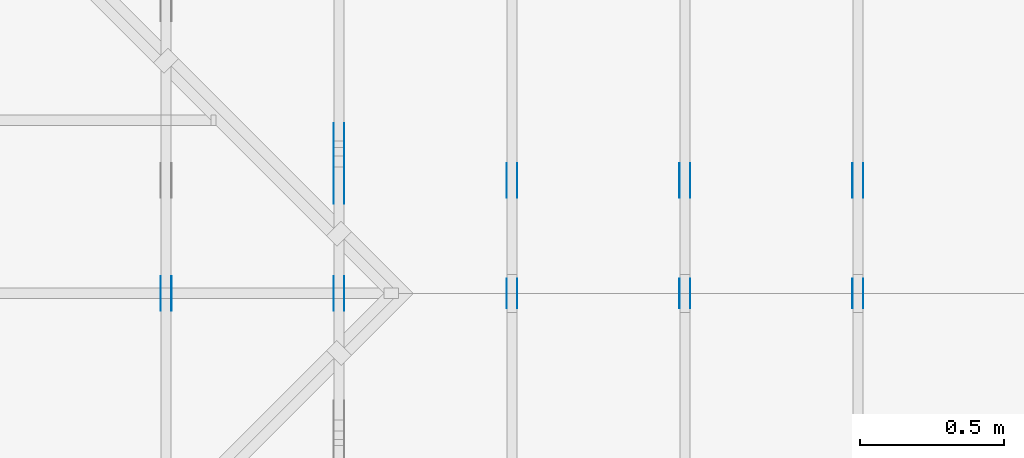
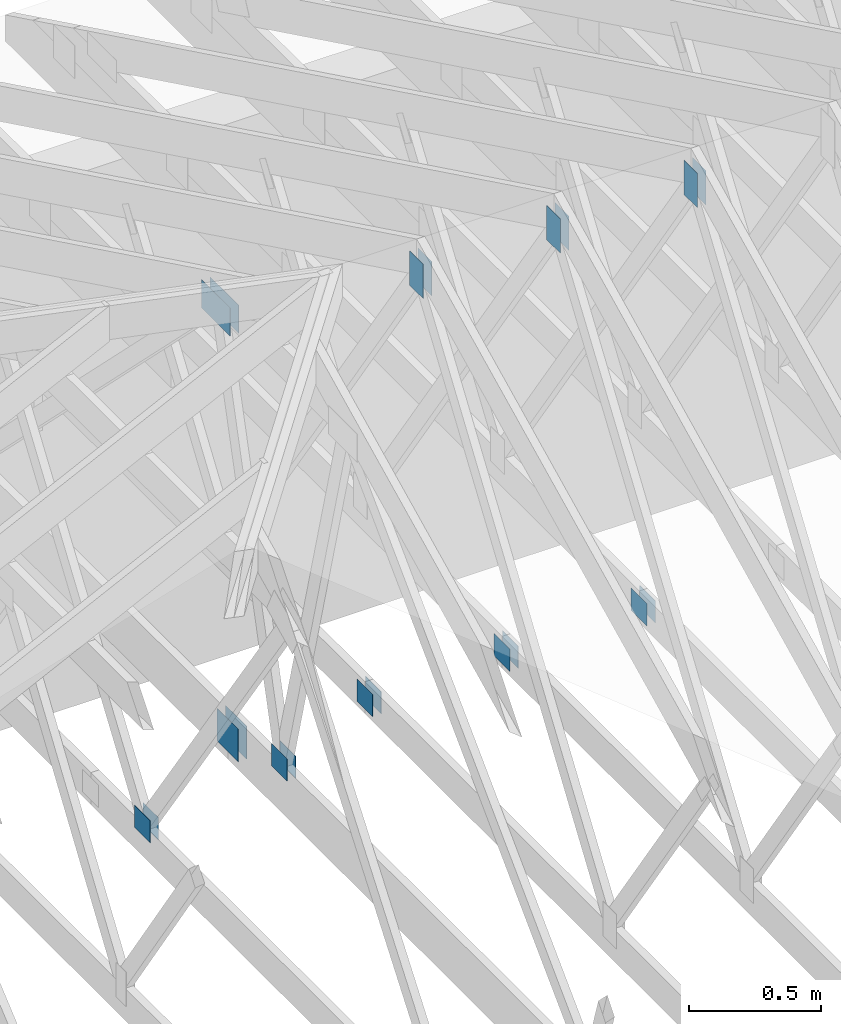
# One storey, part 70 of 159: 20 plates, 5 elements without a shape of their own.
"""IFC2X3 building model written with IfcOpenShell, lengths in millimetres."""

from ifc_helpers import new_model, si_unit, frame, origin, origin_with_axes, origin_2d, place, context, project, spatial, faceted_brep, element, aggregate, save


model = new_model("IFC2X3")

# Units and contexts
model_context = context("Model", 3, precision=1e-05, world=origin())
plan_context = context("Plan", 2, precision=1e-05, world=origin_2d())
ifc_project = project(units=[si_unit("LENGTHUNIT", "METRE", prefix="MILLI"), si_unit("AREAUNIT", "SQUARE_METRE"), si_unit("VOLUMEUNIT", "CUBIC_METRE"), si_unit("SOLIDANGLEUNIT", "STERADIAN"), si_unit("PLANEANGLEUNIT", "RADIAN"), si_unit("MASSUNIT", "GRAM"), si_unit("TIMEUNIT", "SECOND"), si_unit("THERMODYNAMICTEMPERATUREUNIT", "DEGREE_CELSIUS"), si_unit("LUMINOUSINTENSITYUNIT", "LUMEN")], contexts=[model_context, plan_context])

# Site, building, storey
site_placement = place(None, origin_with_axes())
site = spatial("IfcSite", under=ifc_project, at=site_placement, CompositionType="ELEMENT")
building_placement = place(site_placement, origin_with_axes())
building = spatial("IfcBuilding", under=site, at=building_placement, Name="Plan 1", CompositionType="ELEMENT")
storey_placement = place(building_placement, origin_with_axes())
storey = spatial("IfcBuildingStorey", under=building, at=storey_placement, Name="Etasje 1", CompositionType="ELEMENT", Elevation=0.0)

# Assembly, plates
assembly_1_placement = place(storey_placement, frame((5475.0222614047525, 9699.99999999999, 1.1021457184401395e-15), z_axis=(-1.0, 1.836909530733566e-16, 6.123031769111886e-17), x_axis=(-1.836909530733566e-16, -1.0, 0.0)))
assembly_1 = element("IfcElementAssembly", 1, at=assembly_1_placement, inside=storey, Name="T1 (87)", AssemblyPlace="FACTORY", PredefinedType="TRUSS")
plate_1_placement = place(assembly_1_placement, frame((5148.499465064736, 2571.044189453125, 0.0), z_axis=(0.0, 0.0, 1.0), x_axis=(6.123031769111886e-17, -1.0, 0.0)))
plate_1 = element("IfcPlate", 2, at=plate_1_placement, Name="GNT100S 103x159", context=model_context, shape_type="Brep", body=[
    faceted_brep([(159.0, 103.00004665401411, 1.0), (0.0, 103.00004665401411, 1.0), (0.0, 4.6654014113300946e-05, 1.0), (159.0, 4.6654014113300946e-05, 1.0), (0.0, 103.00004665401411, 0.0), (159.0, 103.00004665401411, 1.9471241025775798e-14), (159.0, 4.6654014113300946e-05, 1.9471241025775798e-14), (0.0, 4.6654014113300946e-05, 0.0), (159.00007700547576, -2.920687568387293e-14, 1.788346276888554e-30), (159.00007700547576, -2.914564536618181e-14, 1.0), (7.700547575950623e-05, 6.121617248188473e-17, 1.0), (7.700547575950623e-05, -1.4145209234130956e-20, 8.661156552131866e-37), (159.00007700547576, 103.0, 0.0), (159.00007700547576, 103.0, 1.0), (159.00007700547576, 0.0, 1.0), (159.00007700547576, 0.0, 0.0), (7.700547575950623e-05, 103.0, 0.0), (7.700547575950623e-05, 103.0, 1.0), (159.00007700547576, 102.99999999999999, 1.0), (159.00007700547576, 102.99999999999999, -7.888609052210118e-31), (7.700547575950623e-05, 0.0, 0.0), (7.700547575956746e-05, -7.498303609110687e-33, 1.0), (7.70054757721809e-05, 103.0, 1.0), (7.700547577211967e-05, 103.0, -7.723249910891245e-31)], [[[0, 1, 2, 3]], [[4, 5, 6, 7]], [[8, 9, 10, 11]], [[12, 13, 14, 15]], [[16, 17, 18, 19]], [[20, 21, 22, 23]]]),
])
plate_2_placement = place(assembly_1_placement, frame((5148.499465064736, 2571.044189453125, -37.0), z_axis=(0.0, 0.0, 1.0), x_axis=(6.123031769111886e-17, -1.0, 0.0)))
plate_2 = element("IfcPlate", 3, at=plate_2_placement, Name="GNT100S 103x159", context=model_context, shape_type="Brep", body=[
    faceted_brep([(159.0, 103.00004665401411, 1.0), (0.0, 103.00004665401411, 1.0), (0.0, 4.6654014113300946e-05, 1.0), (159.0, 4.6654014113300946e-05, 1.0), (0.0, 103.00004665401411, 0.0), (159.0, 103.00004665401411, 1.9471241025775798e-14), (159.0, 4.6654014113300946e-05, 1.9471241025775798e-14), (0.0, 4.6654014113300946e-05, 0.0), (159.00007700547576, -2.920687568387293e-14, 1.788346276888554e-30), (159.00007700547576, -2.914564536618181e-14, 1.0), (7.700547575950623e-05, 6.121617248188473e-17, 1.0), (7.700547575950623e-05, -1.4145209234130956e-20, 8.661156552131866e-37), (159.00007700547576, 103.0, 0.0), (159.00007700547576, 103.0, 1.0), (159.00007700547576, 0.0, 1.0), (159.00007700547576, 0.0, 0.0), (7.700547575950623e-05, 103.0, 0.0), (7.700547575950623e-05, 103.0, 1.0), (159.00007700547576, 102.99999999999999, 1.0), (159.00007700547576, 102.99999999999999, -7.888609052210118e-31), (7.700547575950623e-05, 0.0, 0.0), (7.700547575956746e-05, -7.498303609110687e-33, 1.0), (7.70054757721809e-05, 103.0, 1.0), (7.700547577211967e-05, 103.0, -7.723249910891245e-31)], [[[0, 1, 2, 3]], [[4, 5, 6, 7]], [[8, 9, 10, 11]], [[12, 13, 14, 15]], [[16, 17, 18, 19]], [[20, 21, 22, 23]]]),
])
plate_3_placement = place(assembly_1_placement, frame((4868.31787109375, 348.5000000000005, 0.0), z_axis=(0.0, 0.0, 1.0), x_axis=(-1.0, 1.2246063538223773e-16, 0.0)))
plate_3 = element("IfcPlate", 4, at=plate_3_placement, Name="GNT100S 103x119", context=model_context, shape_type="Brep", body=[
    faceted_brep([(119.0, 103.00000000000048, 1.0), (0.0, 103.00000000000048, 1.0), (0.0, 5.115907697472721e-13, 1.0), (119.0, 5.115907697472721e-13, 1.0), (0.0, 103.00000000000048, 0.0), (119.0, 103.00000000000048, 1.457281561048629e-14), (119.0, 5.115907697472721e-13, 1.457281561048629e-14), (0.0, 5.115907697472721e-13, 0.0), (119.00023664694709, -2.1859266885632685e-14, 1.3384498559022438e-30), (119.00023664694709, -2.1798036567941566e-14, 1.0), (0.00023664694708713796, 6.118684778786653e-17, 1.0), (0.00023664694708713796, -4.346990325233656e-20, 2.6616759861427686e-36), (119.00023664694709, 103.0, 0.0), (119.00023664694709, 103.0, 1.0), (119.00023664694709, 0.0, 1.0), (119.00023664694709, 0.0, 0.0), (0.00023664694708713796, 102.99999999999997, 0.0), (0.00023664694708713796, 102.99999999999997, 1.0), (119.00023664694709, 102.99999999999999, 1.0), (119.00023664694709, 102.99999999999999, -7.888609052210118e-31), (0.00023664694708713796, 0.0, 0.0), (0.0002366469470871992, -7.498303609110687e-33, 1.0), (0.00023664694709981264, 102.99999999999997, 1.0), (0.0002366469470997514, 102.99999999999997, -7.723249910891245e-31)], [[[0, 1, 2, 3]], [[4, 5, 6, 7]], [[8, 9, 10, 11]], [[12, 13, 14, 15]], [[16, 17, 18, 19]], [[20, 21, 22, 23]]]),
])
plate_4_placement = place(assembly_1_placement, frame((4868.31787109375, 348.5000000000005, -37.0), z_axis=(0.0, 0.0, 1.0), x_axis=(-1.0, 1.2246063538223773e-16, 0.0)))
plate_4 = element("IfcPlate", 5, at=plate_4_placement, Name="GNT100S 103x119", context=model_context, shape_type="Brep", body=[
    faceted_brep([(119.0, 103.00000000000048, 1.0), (0.0, 103.00000000000048, 1.0), (0.0, 5.115907697472721e-13, 1.0), (119.0, 5.115907697472721e-13, 1.0), (0.0, 103.00000000000048, 0.0), (119.0, 103.00000000000048, 1.457281561048629e-14), (119.0, 5.115907697472721e-13, 1.457281561048629e-14), (0.0, 5.115907697472721e-13, 0.0), (119.00023664694709, -2.1859266885632685e-14, 1.3384498559022438e-30), (119.00023664694709, -2.1798036567941566e-14, 1.0), (0.00023664694708713796, 6.118684778786653e-17, 1.0), (0.00023664694708713796, -4.346990325233656e-20, 2.6616759861427686e-36), (119.00023664694709, 103.0, 0.0), (119.00023664694709, 103.0, 1.0), (119.00023664694709, 0.0, 1.0), (119.00023664694709, 0.0, 0.0), (0.00023664694708713796, 102.99999999999997, 0.0), (0.00023664694708713796, 102.99999999999997, 1.0), (119.00023664694709, 102.99999999999999, 1.0), (119.00023664694709, 102.99999999999999, -7.888609052210118e-31), (0.00023664694708713796, 0.0, 0.0), (0.0002366469470871992, -7.498303609110687e-33, 1.0), (0.00023664694709981264, 102.99999999999997, 1.0), (0.0002366469470997514, 102.99999999999997, -7.723249910891245e-31)], [[[0, 1, 2, 3]], [[4, 5, 6, 7]], [[8, 9, 10, 11]], [[12, 13, 14, 15]], [[16, 17, 18, 19]], [[20, 21, 22, 23]]]),
])
aggregate(assembly_1, [plate_1, plate_2, plate_3, plate_4])

assembly_2_placement = place(storey_placement, frame((4875.0222614047525, 9699.99999999999, 1.1021457184401395e-15), z_axis=(-1.0, 1.836909530733566e-16, 6.123031769111886e-17), x_axis=(-1.836909530733566e-16, -1.0, 0.0)))
assembly_2 = element("IfcElementAssembly", 6, at=assembly_2_placement, inside=storey, Name="T1 (86)", AssemblyPlace="FACTORY", PredefinedType="TRUSS")
plate_5_placement = place(assembly_2_placement, frame((5148.499465064736, 2571.044189453125, 0.0), z_axis=(0.0, 0.0, 1.0), x_axis=(6.123031769111886e-17, -1.0, 0.0)))
plate_5 = element("IfcPlate", 7, at=plate_5_placement, Name="GNT100S 103x159", context=model_context, shape_type="Brep", body=[
    faceted_brep([(159.0, 103.00004665401411, 1.0), (0.0, 103.00004665401411, 1.0), (0.0, 4.6654014113300946e-05, 1.0), (159.0, 4.6654014113300946e-05, 1.0), (0.0, 103.00004665401411, 0.0), (159.0, 103.00004665401411, 1.9471241025775798e-14), (159.0, 4.6654014113300946e-05, 1.9471241025775798e-14), (0.0, 4.6654014113300946e-05, 0.0), (159.00007700547576, -2.920687568387293e-14, 1.788346276888554e-30), (159.00007700547576, -2.914564536618181e-14, 1.0), (7.700547575950623e-05, 6.121617248188473e-17, 1.0), (7.700547575950623e-05, -1.4145209234130956e-20, 8.661156552131866e-37), (159.00007700547576, 103.0, 0.0), (159.00007700547576, 103.0, 1.0), (159.00007700547576, 0.0, 1.0), (159.00007700547576, 0.0, 0.0), (7.700547575950623e-05, 103.0, 0.0), (7.700547575950623e-05, 103.0, 1.0), (159.00007700547576, 102.99999999999999, 1.0), (159.00007700547576, 102.99999999999999, -7.888609052210118e-31), (7.700547575950623e-05, 0.0, 0.0), (7.700547575956746e-05, -7.498303609110687e-33, 1.0), (7.70054757721809e-05, 103.0, 1.0), (7.700547577211967e-05, 103.0, -7.723249910891245e-31)], [[[0, 1, 2, 3]], [[4, 5, 6, 7]], [[8, 9, 10, 11]], [[12, 13, 14, 15]], [[16, 17, 18, 19]], [[20, 21, 22, 23]]]),
])
plate_6_placement = place(assembly_2_placement, frame((5148.499465064736, 2571.044189453125, -37.0), z_axis=(0.0, 0.0, 1.0), x_axis=(6.123031769111886e-17, -1.0, 0.0)))
plate_6 = element("IfcPlate", 8, at=plate_6_placement, Name="GNT100S 103x159", context=model_context, shape_type="Brep", body=[
    faceted_brep([(159.0, 103.00004665401411, 1.0), (0.0, 103.00004665401411, 1.0), (0.0, 4.6654014113300946e-05, 1.0), (159.0, 4.6654014113300946e-05, 1.0), (0.0, 103.00004665401411, 0.0), (159.0, 103.00004665401411, 1.9471241025775798e-14), (159.0, 4.6654014113300946e-05, 1.9471241025775798e-14), (0.0, 4.6654014113300946e-05, 0.0), (159.00007700547576, -2.920687568387293e-14, 1.788346276888554e-30), (159.00007700547576, -2.914564536618181e-14, 1.0), (7.700547575950623e-05, 6.121617248188473e-17, 1.0), (7.700547575950623e-05, -1.4145209234130956e-20, 8.661156552131866e-37), (159.00007700547576, 103.0, 0.0), (159.00007700547576, 103.0, 1.0), (159.00007700547576, 0.0, 1.0), (159.00007700547576, 0.0, 0.0), (7.700547575950623e-05, 103.0, 0.0), (7.700547575950623e-05, 103.0, 1.0), (159.00007700547576, 102.99999999999999, 1.0), (159.00007700547576, 102.99999999999999, -7.888609052210118e-31), (7.700547575950623e-05, 0.0, 0.0), (7.700547575956746e-05, -7.498303609110687e-33, 1.0), (7.70054757721809e-05, 103.0, 1.0), (7.700547577211967e-05, 103.0, -7.723249910891245e-31)], [[[0, 1, 2, 3]], [[4, 5, 6, 7]], [[8, 9, 10, 11]], [[12, 13, 14, 15]], [[16, 17, 18, 19]], [[20, 21, 22, 23]]]),
])
plate_7_placement = place(assembly_2_placement, frame((4868.31787109375, 348.5000000000005, 0.0), z_axis=(0.0, 0.0, 1.0), x_axis=(-1.0, 1.2246063538223773e-16, 0.0)))
plate_7 = element("IfcPlate", 9, at=plate_7_placement, Name="GNT100S 103x119", context=model_context, shape_type="Brep", body=[
    faceted_brep([(119.0, 103.00000000000048, 1.0), (0.0, 103.00000000000048, 1.0), (0.0, 5.115907697472721e-13, 1.0), (119.0, 5.115907697472721e-13, 1.0), (0.0, 103.00000000000048, 0.0), (119.0, 103.00000000000048, 1.457281561048629e-14), (119.0, 5.115907697472721e-13, 1.457281561048629e-14), (0.0, 5.115907697472721e-13, 0.0), (119.00023664694709, -2.1859266885632685e-14, 1.3384498559022438e-30), (119.00023664694709, -2.1798036567941566e-14, 1.0), (0.00023664694708713796, 6.118684778786653e-17, 1.0), (0.00023664694708713796, -4.346990325233656e-20, 2.6616759861427686e-36), (119.00023664694709, 103.0, 0.0), (119.00023664694709, 103.0, 1.0), (119.00023664694709, 0.0, 1.0), (119.00023664694709, 0.0, 0.0), (0.00023664694708713796, 102.99999999999997, 0.0), (0.00023664694708713796, 102.99999999999997, 1.0), (119.00023664694709, 102.99999999999999, 1.0), (119.00023664694709, 102.99999999999999, -7.888609052210118e-31), (0.00023664694708713796, 0.0, 0.0), (0.0002366469470871992, -7.498303609110687e-33, 1.0), (0.00023664694709981264, 102.99999999999997, 1.0), (0.0002366469470997514, 102.99999999999997, -7.723249910891245e-31)], [[[0, 1, 2, 3]], [[4, 5, 6, 7]], [[8, 9, 10, 11]], [[12, 13, 14, 15]], [[16, 17, 18, 19]], [[20, 21, 22, 23]]]),
])
plate_8_placement = place(assembly_2_placement, frame((4868.31787109375, 348.5000000000005, -37.0), z_axis=(0.0, 0.0, 1.0), x_axis=(-1.0, 1.2246063538223773e-16, 0.0)))
plate_8 = element("IfcPlate", 10, at=plate_8_placement, Name="GNT100S 103x119", context=model_context, shape_type="Brep", body=[
    faceted_brep([(119.0, 103.00000000000048, 1.0), (0.0, 103.00000000000048, 1.0), (0.0, 5.115907697472721e-13, 1.0), (119.0, 5.115907697472721e-13, 1.0), (0.0, 103.00000000000048, 0.0), (119.0, 103.00000000000048, 1.457281561048629e-14), (119.0, 5.115907697472721e-13, 1.457281561048629e-14), (0.0, 5.115907697472721e-13, 0.0), (119.00023664694709, -2.1859266885632685e-14, 1.3384498559022438e-30), (119.00023664694709, -2.1798036567941566e-14, 1.0), (0.00023664694708713796, 6.118684778786653e-17, 1.0), (0.00023664694708713796, -4.346990325233656e-20, 2.6616759861427686e-36), (119.00023664694709, 103.0, 0.0), (119.00023664694709, 103.0, 1.0), (119.00023664694709, 0.0, 1.0), (119.00023664694709, 0.0, 0.0), (0.00023664694708713796, 102.99999999999997, 0.0), (0.00023664694708713796, 102.99999999999997, 1.0), (119.00023664694709, 102.99999999999999, 1.0), (119.00023664694709, 102.99999999999999, -7.888609052210118e-31), (0.00023664694708713796, 0.0, 0.0), (0.0002366469470871992, -7.498303609110687e-33, 1.0), (0.00023664694709981264, 102.99999999999997, 1.0), (0.0002366469470997514, 102.99999999999997, -7.723249910891245e-31)], [[[0, 1, 2, 3]], [[4, 5, 6, 7]], [[8, 9, 10, 11]], [[12, 13, 14, 15]], [[16, 17, 18, 19]], [[20, 21, 22, 23]]]),
])
aggregate(assembly_2, [plate_5, plate_6, plate_7, plate_8])

assembly_3_placement = place(storey_placement, frame((3675.02226140475, 9699.999999999993, 1.1021457184401395e-15), z_axis=(-1.0, 1.836909530733566e-16, 6.123031769111886e-17), x_axis=(-1.836909530733566e-16, -1.0, 0.0)))
assembly_3 = element("IfcElementAssembly", 11, at=assembly_3_placement, inside=storey, Name="V4 (5)", AssemblyPlace="FACTORY", PredefinedType="TRUSS")
plate_9_placement = place(assembly_3_placement, frame((5140.4994650659755, 319.5, 0.0), z_axis=(0.0, 0.0, 1.0), x_axis=(1.0, 0.0, 0.0)))
plate_9 = element("IfcPlate", 12, at=plate_9_placement, Name="GNT100S 103x119", context=model_context, shape_type="Brep", body=[
    faceted_brep([(119.00004665277447, 103.0, 1.0), (4.665277447202243e-05, 103.0, 1.0), (4.665277447202243e-05, 0.0, 1.0), (119.00004665277447, 0.0, 1.0), (4.665277447202243e-05, 103.0, 5.713128404188107e-21), (119.00004665277447, 103.0, 1.4572821323614695e-14), (119.00004665277447, 0.0, 1.4572821323614695e-14), (4.665277447202243e-05, 0.0, 5.713128404188107e-21), (119.0, 3.7604470860992667e-13, 1.3384471942262577e-30), (119.0, 3.761059389276178e-13, 1.0), (1.1247455413666031e-32, 3.979651623433472e-13, 1.0), (0.0, 3.979039320256561e-13, 0.0), (119.0, 103.0000000000004, 0.0), (119.0, 103.0000000000004, 1.0), (119.0, 3.979039320256561e-13, 1.0), (119.0, 3.979039320256561e-13, 0.0), (0.0, 103.0000000000004, 0.0), (-3.7491518045553436e-33, 103.0000000000004, 1.0), (119.0, 103.00000000000038, 1.0), (119.0, 103.00000000000038, -7.888609052210118e-31), (4.8727568336952577e-29, 3.979039320256561e-13, -2.983604489587311e-45), (6.123031769116759e-17, 3.979039320256561e-13, 1.0), (1.2674675762061654e-14, 103.0000000000004, 1.0), (1.2613445444370535e-14, 103.0000000000004, -7.723252717384038e-31)], [[[0, 1, 2, 3]], [[4, 5, 6, 7]], [[8, 9, 10, 11]], [[12, 13, 14, 15]], [[16, 17, 18, 19]], [[20, 21, 22, 23]]]),
])
plate_10_placement = place(assembly_3_placement, frame((5140.4994650659755, 319.5, -37.0), z_axis=(0.0, 0.0, 1.0), x_axis=(1.0, 0.0, 0.0)))
plate_10 = element("IfcPlate", 13, at=plate_10_placement, Name="GNT100S 103x119", context=model_context, shape_type="Brep", body=[
    faceted_brep([(119.00004665277447, 103.0, 1.0), (4.665277447202243e-05, 103.0, 1.0), (4.665277447202243e-05, 0.0, 1.0), (119.00004665277447, 0.0, 1.0), (4.665277447202243e-05, 103.0, 5.713128404188107e-21), (119.00004665277447, 103.0, 1.4572821323614695e-14), (119.00004665277447, 0.0, 1.4572821323614695e-14), (4.665277447202243e-05, 0.0, 5.713128404188107e-21), (119.0, 3.7604470860992667e-13, 1.3384471942262577e-30), (119.0, 3.761059389276178e-13, 1.0), (1.1247455413666031e-32, 3.979651623433472e-13, 1.0), (0.0, 3.979039320256561e-13, 0.0), (119.0, 103.0000000000004, 0.0), (119.0, 103.0000000000004, 1.0), (119.0, 3.979039320256561e-13, 1.0), (119.0, 3.979039320256561e-13, 0.0), (0.0, 103.0000000000004, 0.0), (-3.7491518045553436e-33, 103.0000000000004, 1.0), (119.0, 103.00000000000038, 1.0), (119.0, 103.00000000000038, -7.888609052210118e-31), (4.8727568336952577e-29, 3.979039320256561e-13, -2.983604489587311e-45), (6.123031769116759e-17, 3.979039320256561e-13, 1.0), (1.2674675762061654e-14, 103.0000000000004, 1.0), (1.2613445444370535e-14, 103.0000000000004, -7.723252717384038e-31)], [[[0, 1, 2, 3]], [[4, 5, 6, 7]], [[8, 9, 10, 11]], [[12, 13, 14, 15]], [[16, 17, 18, 19]], [[20, 21, 22, 23]]]),
])
aggregate(assembly_3, [plate_9, plate_10])

assembly_4_placement = place(storey_placement, frame((6075.0222614047525, 9699.99999999999, 1.1021457184401395e-15), z_axis=(-1.0, 1.836909530733566e-16, 6.123031769111886e-17), x_axis=(-1.836909530733566e-16, -1.0, 0.0)))
assembly_4 = element("IfcElementAssembly", 14, at=assembly_4_placement, inside=storey, Name="T1 (88)", AssemblyPlace="FACTORY", PredefinedType="TRUSS")
plate_11_placement = place(assembly_4_placement, frame((5148.499465064736, 2571.044189453125, 0.0), z_axis=(0.0, 0.0, 1.0), x_axis=(6.123031769111886e-17, -1.0, 0.0)))
plate_11 = element("IfcPlate", 15, at=plate_11_placement, Name="GNT100S 103x159", context=model_context, shape_type="Brep", body=[
    faceted_brep([(159.0, 103.00004665401411, 1.0), (0.0, 103.00004665401411, 1.0), (0.0, 4.6654014113300946e-05, 1.0), (159.0, 4.6654014113300946e-05, 1.0), (0.0, 103.00004665401411, 0.0), (159.0, 103.00004665401411, 1.9471241025775798e-14), (159.0, 4.6654014113300946e-05, 1.9471241025775798e-14), (0.0, 4.6654014113300946e-05, 0.0), (159.00007700547576, -2.920687568387293e-14, 1.788346276888554e-30), (159.00007700547576, -2.914564536618181e-14, 1.0), (7.700547575950623e-05, 6.121617248188473e-17, 1.0), (7.700547575950623e-05, -1.4145209234130956e-20, 8.661156552131866e-37), (159.00007700547576, 103.0, 0.0), (159.00007700547576, 103.0, 1.0), (159.00007700547576, 0.0, 1.0), (159.00007700547576, 0.0, 0.0), (7.700547575950623e-05, 103.0, 0.0), (7.700547575950623e-05, 103.0, 1.0), (159.00007700547576, 102.99999999999999, 1.0), (159.00007700547576, 102.99999999999999, -7.888609052210118e-31), (7.700547575950623e-05, 0.0, 0.0), (7.700547575956746e-05, -7.498303609110687e-33, 1.0), (7.70054757721809e-05, 103.0, 1.0), (7.700547577211967e-05, 103.0, -7.723249910891245e-31)], [[[0, 1, 2, 3]], [[4, 5, 6, 7]], [[8, 9, 10, 11]], [[12, 13, 14, 15]], [[16, 17, 18, 19]], [[20, 21, 22, 23]]]),
])
plate_12_placement = place(assembly_4_placement, frame((5148.499465064736, 2571.044189453125, -37.0), z_axis=(0.0, 0.0, 1.0), x_axis=(6.123031769111886e-17, -1.0, 0.0)))
plate_12 = element("IfcPlate", 16, at=plate_12_placement, Name="GNT100S 103x159", context=model_context, shape_type="Brep", body=[
    faceted_brep([(159.0, 103.00004665401411, 1.0), (0.0, 103.00004665401411, 1.0), (0.0, 4.6654014113300946e-05, 1.0), (159.0, 4.6654014113300946e-05, 1.0), (0.0, 103.00004665401411, 0.0), (159.0, 103.00004665401411, 1.9471241025775798e-14), (159.0, 4.6654014113300946e-05, 1.9471241025775798e-14), (0.0, 4.6654014113300946e-05, 0.0), (159.00007700547576, -2.920687568387293e-14, 1.788346276888554e-30), (159.00007700547576, -2.914564536618181e-14, 1.0), (7.700547575950623e-05, 6.121617248188473e-17, 1.0), (7.700547575950623e-05, -1.4145209234130956e-20, 8.661156552131866e-37), (159.00007700547576, 103.0, 0.0), (159.00007700547576, 103.0, 1.0), (159.00007700547576, 0.0, 1.0), (159.00007700547576, 0.0, 0.0), (7.700547575950623e-05, 103.0, 0.0), (7.700547575950623e-05, 103.0, 1.0), (159.00007700547576, 102.99999999999999, 1.0), (159.00007700547576, 102.99999999999999, -7.888609052210118e-31), (7.700547575950623e-05, 0.0, 0.0), (7.700547575956746e-05, -7.498303609110687e-33, 1.0), (7.70054757721809e-05, 103.0, 1.0), (7.700547577211967e-05, 103.0, -7.723249910891245e-31)], [[[0, 1, 2, 3]], [[4, 5, 6, 7]], [[8, 9, 10, 11]], [[12, 13, 14, 15]], [[16, 17, 18, 19]], [[20, 21, 22, 23]]]),
])
plate_13_placement = place(assembly_4_placement, frame((4868.31787109375, 348.5000000000005, 0.0), z_axis=(0.0, 0.0, 1.0), x_axis=(-1.0, 1.2246063538223773e-16, 0.0)))
plate_13 = element("IfcPlate", 17, at=plate_13_placement, Name="GNT100S 103x119", context=model_context, shape_type="Brep", body=[
    faceted_brep([(119.0, 103.00000000000048, 1.0), (0.0, 103.00000000000048, 1.0), (0.0, 5.115907697472721e-13, 1.0), (119.0, 5.115907697472721e-13, 1.0), (0.0, 103.00000000000048, 0.0), (119.0, 103.00000000000048, 1.457281561048629e-14), (119.0, 5.115907697472721e-13, 1.457281561048629e-14), (0.0, 5.115907697472721e-13, 0.0), (119.00023664694709, -2.1859266885632685e-14, 1.3384498559022438e-30), (119.00023664694709, -2.1798036567941566e-14, 1.0), (0.00023664694708713796, 6.118684778786653e-17, 1.0), (0.00023664694708713796, -4.346990325233656e-20, 2.6616759861427686e-36), (119.00023664694709, 103.0, 0.0), (119.00023664694709, 103.0, 1.0), (119.00023664694709, 0.0, 1.0), (119.00023664694709, 0.0, 0.0), (0.00023664694708713796, 102.99999999999997, 0.0), (0.00023664694708713796, 102.99999999999997, 1.0), (119.00023664694709, 102.99999999999999, 1.0), (119.00023664694709, 102.99999999999999, -7.888609052210118e-31), (0.00023664694708713796, 0.0, 0.0), (0.0002366469470871992, -7.498303609110687e-33, 1.0), (0.00023664694709981264, 102.99999999999997, 1.0), (0.0002366469470997514, 102.99999999999997, -7.723249910891245e-31)], [[[0, 1, 2, 3]], [[4, 5, 6, 7]], [[8, 9, 10, 11]], [[12, 13, 14, 15]], [[16, 17, 18, 19]], [[20, 21, 22, 23]]]),
])
plate_14_placement = place(assembly_4_placement, frame((4868.31787109375, 348.5000000000005, -37.0), z_axis=(0.0, 0.0, 1.0), x_axis=(-1.0, 1.2246063538223773e-16, 0.0)))
plate_14 = element("IfcPlate", 18, at=plate_14_placement, Name="GNT100S 103x119", context=model_context, shape_type="Brep", body=[
    faceted_brep([(119.0, 103.00000000000048, 1.0), (0.0, 103.00000000000048, 1.0), (0.0, 5.115907697472721e-13, 1.0), (119.0, 5.115907697472721e-13, 1.0), (0.0, 103.00000000000048, 0.0), (119.0, 103.00000000000048, 1.457281561048629e-14), (119.0, 5.115907697472721e-13, 1.457281561048629e-14), (0.0, 5.115907697472721e-13, 0.0), (119.00023664694709, -2.1859266885632685e-14, 1.3384498559022438e-30), (119.00023664694709, -2.1798036567941566e-14, 1.0), (0.00023664694708713796, 6.118684778786653e-17, 1.0), (0.00023664694708713796, -4.346990325233656e-20, 2.6616759861427686e-36), (119.00023664694709, 103.0, 0.0), (119.00023664694709, 103.0, 1.0), (119.00023664694709, 0.0, 1.0), (119.00023664694709, 0.0, 0.0), (0.00023664694708713796, 102.99999999999997, 0.0), (0.00023664694708713796, 102.99999999999997, 1.0), (119.00023664694709, 102.99999999999999, 1.0), (119.00023664694709, 102.99999999999999, -7.888609052210118e-31), (0.00023664694708713796, 0.0, 0.0), (0.0002366469470871992, -7.498303609110687e-33, 1.0), (0.00023664694709981264, 102.99999999999997, 1.0), (0.0002366469470997514, 102.99999999999997, -7.723249910891245e-31)], [[[0, 1, 2, 3]], [[4, 5, 6, 7]], [[8, 9, 10, 11]], [[12, 13, 14, 15]], [[16, 17, 18, 19]], [[20, 21, 22, 23]]]),
])
aggregate(assembly_4, [plate_11, plate_12, plate_13, plate_14])

assembly_5_placement = place(storey_placement, frame((4275.022261406632, 9700.000260373617, 1.1021457184401395e-15), z_axis=(-0.999999999895379, 1.4465201327097478e-05, 6.123031769111886e-17), x_axis=(-1.4465201327097478e-05, -0.999999999895379, 0.0)))
assembly_5 = element("IfcElementAssembly", 19, at=assembly_5_placement, inside=storey, Name="V13 (6)", AssemblyPlace="FACTORY", PredefinedType="TRUSS")
plate_15_placement = place(assembly_5_placement, frame((4609.239104328739, 2191.573884398309, 0.0), z_axis=(0.0, 0.0, 1.0), x_axis=(1.0, 0.0, 0.0)))
plate_15 = element("IfcPlate", 20, at=plate_15_placement, Name="GNT100S 130x218", context=model_context, shape_type="Brep", body=[
    faceted_brep([(218.0001534837611, 130.00009021106598, 1.0), (0.00015348376109614037, 130.00009021106598, 1.0), (0.00015348376109614037, 9.021106598083861e-05, 1.0), (218.0001534837611, 9.021106598083861e-05, 1.0), (0.00015348376109614037, 130.00009021106598, 1.879571890468893e-20), (218.0001534837611, 130.00009021106598, 2.669643730904673e-14), (218.0001534837611, 9.021106598083861e-05, 2.669643730904673e-14), (0.00015348376109614037, 9.021106598083861e-05, 1.879571890468893e-20), (218.0, -4.0044627769991736e-14, 2.4519452801791947e-30), (218.0, -3.998339745230062e-14, 1.0), (1.1247455413666031e-32, 6.123031769111886e-17, 1.0), (0.0, 0.0, 0.0), (218.0, 130.0, 0.0), (218.0, 130.0, 1.0), (218.0, 0.0, 1.0), (218.0, 0.0, 0.0), (0.0, 130.0, 0.0), (-3.7491518045553436e-33, 130.0, 1.0), (218.0, 130.0, 1.0), (218.0, 130.0, -1.5777218104420236e-30), (0.0, 0.0, 0.0), (6.123031769111886e-17, -7.498303609110687e-33, 1.0), (1.5981112917382023e-14, 130.0, 1.0), (1.5919882599690904e-14, 130.0, -9.747794691843893e-31)], [[[0, 1, 2, 3]], [[4, 5, 6, 7]], [[8, 9, 10, 11]], [[12, 13, 14, 15]], [[16, 17, 18, 19]], [[20, 21, 22, 23]]]),
])
plate_16_placement = place(assembly_5_placement, frame((4609.239104328739, 2191.573884398309, -37.0), z_axis=(0.0, 0.0, 1.0), x_axis=(1.0, 0.0, 0.0)))
plate_16 = element("IfcPlate", 21, at=plate_16_placement, Name="GNT100S 130x218", context=model_context, shape_type="Brep", body=[
    faceted_brep([(218.0001534837611, 130.00009021106598, 1.0), (0.00015348376109614037, 130.00009021106598, 1.0), (0.00015348376109614037, 9.021106598083861e-05, 1.0), (218.0001534837611, 9.021106598083861e-05, 1.0), (0.00015348376109614037, 130.00009021106598, 1.879571890468893e-20), (218.0001534837611, 130.00009021106598, 2.669643730904673e-14), (218.0001534837611, 9.021106598083861e-05, 2.669643730904673e-14), (0.00015348376109614037, 9.021106598083861e-05, 1.879571890468893e-20), (218.0, -4.0044627769991736e-14, 2.4519452801791947e-30), (218.0, -3.998339745230062e-14, 1.0), (1.1247455413666031e-32, 6.123031769111886e-17, 1.0), (0.0, 0.0, 0.0), (218.0, 130.0, 0.0), (218.0, 130.0, 1.0), (218.0, 0.0, 1.0), (218.0, 0.0, 0.0), (0.0, 130.0, 0.0), (-3.7491518045553436e-33, 130.0, 1.0), (218.0, 130.0, 1.0), (218.0, 130.0, -1.5777218104420236e-30), (0.0, 0.0, 0.0), (6.123031769111886e-17, -7.498303609110687e-33, 1.0), (1.5981112917382023e-14, 130.0, 1.0), (1.5919882599690904e-14, 130.0, -9.747794691843893e-31)], [[[0, 1, 2, 3]], [[4, 5, 6, 7]], [[8, 9, 10, 11]], [[12, 13, 14, 15]], [[16, 17, 18, 19]], [[20, 21, 22, 23]]]),
])
plate_17_placement = place(assembly_5_placement, frame((4888.31787109375, 410.5000000000004, 0.0), z_axis=(0.0, 0.0, 1.0), x_axis=(-1.0, 1.2246063538223773e-16, 0.0)))
plate_17 = element("IfcPlate", 22, at=plate_17_placement, Name="GNT100S 152x159", context=model_context, shape_type="Brep", body=[
    faceted_brep([(159.0, 152.0000000000004, 1.0), (0.0, 152.0000000000004, 1.0), (0.0, 3.979039320256561e-13, 1.0), (159.0, 3.979039320256561e-13, 1.0), (0.0, 152.0000000000004, 0.0), (159.0, 152.0000000000004, 1.9471241025775798e-14), (159.0, 4.547473508864641e-13, 1.9471241025775798e-14), (0.0, 4.547473508864641e-13, 0.0), (159.00023558177145, -2.9206989034748536e-14, 5.268893812895291e-30), (159.00023558177145, -2.914575871705742e-14, 1.0), (0.00023558177144877845, 6.110282160627502e-17, 1.0), (0.00023558177144877845, -1.2749608484384683e-19, 7.806625779362585e-36), (159.00023558177145, 152.00000000000006, 0.0), (159.00023558177145, 152.00000000000006, 1.0), (159.00023558177145, 5.684341886080802e-14, 1.0), (159.00023558177145, 5.684341886080802e-14, 0.0), (0.00023558177144877845, 152.0, 0.0), (0.00023558177144877845, 152.0, 1.0), (159.00023558177145, 152.00000000000006, 1.0), (159.00023558177145, 152.00000000000006, 0.0), (0.00023558177144877845, 0.0, 0.0), (0.00023558177144883968, -7.498303609110687e-33, 1.0), (0.0002355817714674537, 152.0, 1.0), (0.00023558177146739247, 152.0, -1.1397412669640613e-30)], [[[0, 1, 2, 3]], [[4, 5, 6, 7]], [[8, 9, 10, 11]], [[12, 13, 14, 15]], [[16, 17, 18, 19]], [[20, 21, 22, 23]]]),
])
plate_18_placement = place(assembly_5_placement, frame((4888.31787109375, 410.5000000000004, -37.0), z_axis=(0.0, 0.0, 1.0), x_axis=(-1.0, 1.2246063538223773e-16, 0.0)))
plate_18 = element("IfcPlate", 23, at=plate_18_placement, Name="GNT100S 152x159", context=model_context, shape_type="Brep", body=[
    faceted_brep([(159.0, 152.0000000000004, 1.0), (0.0, 152.0000000000004, 1.0), (0.0, 3.979039320256561e-13, 1.0), (159.0, 3.979039320256561e-13, 1.0), (0.0, 152.0000000000004, 0.0), (159.0, 152.0000000000004, 1.9471241025775798e-14), (159.0, 4.547473508864641e-13, 1.9471241025775798e-14), (0.0, 4.547473508864641e-13, 0.0), (159.00023558177145, -2.9206989034748536e-14, 5.268893812895291e-30), (159.00023558177145, -2.914575871705742e-14, 1.0), (0.00023558177144877845, 6.110282160627502e-17, 1.0), (0.00023558177144877845, -1.2749608484384683e-19, 7.806625779362585e-36), (159.00023558177145, 152.00000000000006, 0.0), (159.00023558177145, 152.00000000000006, 1.0), (159.00023558177145, 5.684341886080802e-14, 1.0), (159.00023558177145, 5.684341886080802e-14, 0.0), (0.00023558177144877845, 152.0, 0.0), (0.00023558177144877845, 152.0, 1.0), (159.00023558177145, 152.00000000000006, 1.0), (159.00023558177145, 152.00000000000006, 0.0), (0.00023558177144877845, 0.0, 0.0), (0.00023558177144883968, -7.498303609110687e-33, 1.0), (0.0002355817714674537, 152.0, 1.0), (0.00023558177146739247, 152.0, -1.1397412669640613e-30)], [[[0, 1, 2, 3]], [[4, 5, 6, 7]], [[8, 9, 10, 11]], [[12, 13, 14, 15]], [[16, 17, 18, 19]], [[20, 21, 22, 23]]]),
])
plate_19_placement = place(assembly_5_placement, frame((5140.49946560805, 394.5, 0.0), z_axis=(0.0, 0.0, 1.0), x_axis=(1.0, 0.0, 0.0)))
plate_19 = element("IfcPlate", 24, at=plate_19_placement, Name="GNT100S 103x119", context=model_context, shape_type="Brep", body=[
    faceted_brep([(119.00004611070017, 103.0, 1.0), (4.6110700168355834e-05, 103.0, 1.0), (4.6110700168355834e-05, 0.0, 1.0), (119.00004611070017, 0.0, 1.0), (4.6110700168355834e-05, 103.0, 5.6467456405367115e-21), (119.00004611070017, 103.0, 1.457282125723193e-14), (119.00004611070017, 0.0, 1.457282125723193e-14), (4.6110700168355834e-05, 0.0, 5.6467456405367115e-21), (119.0, 3.1920128974911866e-13, 1.3384471942262577e-30), (119.0, 3.1926252006680977e-13, 1.0), (1.1247455413666031e-32, 3.411217434825392e-13, 1.0), (0.0, 3.410605131648481e-13, 0.0), (119.0, 103.00000000000034, 0.0), (119.0, 103.00000000000034, 1.0), (119.0, 3.410605131648481e-13, 1.0), (119.0, 3.410605131648481e-13, 0.0), (0.0, 103.00000000000034, 0.0), (-3.7491518045553436e-33, 103.00000000000034, 1.0), (119.0, 103.00000000000033, 1.0), (119.0, 103.00000000000033, -7.888609052210118e-31), (4.176648714595935e-29, 3.410605131648481e-13, -2.5573752767891235e-45), (6.123031769116062e-17, 3.410605131648481e-13, 1.0), (1.2674675762061646e-14, 103.00000000000034, 1.0), (1.2613445444370527e-14, 103.00000000000034, -7.723252717384033e-31)], [[[0, 1, 2, 3]], [[4, 5, 6, 7]], [[8, 9, 10, 11]], [[12, 13, 14, 15]], [[16, 17, 18, 19]], [[20, 21, 22, 23]]]),
])
plate_20_placement = place(assembly_5_placement, frame((5140.49946560805, 394.5, -37.0), z_axis=(0.0, 0.0, 1.0), x_axis=(1.0, 0.0, 0.0)))
plate_20 = element("IfcPlate", 25, at=plate_20_placement, Name="GNT100S 103x119", context=model_context, shape_type="Brep", body=[
    faceted_brep([(119.00004611070017, 103.0, 1.0), (4.6110700168355834e-05, 103.0, 1.0), (4.6110700168355834e-05, 0.0, 1.0), (119.00004611070017, 0.0, 1.0), (4.6110700168355834e-05, 103.0, 5.6467456405367115e-21), (119.00004611070017, 103.0, 1.457282125723193e-14), (119.00004611070017, 0.0, 1.457282125723193e-14), (4.6110700168355834e-05, 0.0, 5.6467456405367115e-21), (119.0, 3.1920128974911866e-13, 1.3384471942262577e-30), (119.0, 3.1926252006680977e-13, 1.0), (1.1247455413666031e-32, 3.411217434825392e-13, 1.0), (0.0, 3.410605131648481e-13, 0.0), (119.0, 103.00000000000034, 0.0), (119.0, 103.00000000000034, 1.0), (119.0, 3.410605131648481e-13, 1.0), (119.0, 3.410605131648481e-13, 0.0), (0.0, 103.00000000000034, 0.0), (-3.7491518045553436e-33, 103.00000000000034, 1.0), (119.0, 103.00000000000033, 1.0), (119.0, 103.00000000000033, -7.888609052210118e-31), (4.176648714595935e-29, 3.410605131648481e-13, -2.5573752767891235e-45), (6.123031769116062e-17, 3.410605131648481e-13, 1.0), (1.2674675762061646e-14, 103.00000000000034, 1.0), (1.2613445444370527e-14, 103.00000000000034, -7.723252717384033e-31)], [[[0, 1, 2, 3]], [[4, 5, 6, 7]], [[8, 9, 10, 11]], [[12, 13, 14, 15]], [[16, 17, 18, 19]], [[20, 21, 22, 23]]]),
])
aggregate(assembly_5, [plate_15, plate_16, plate_17, plate_18, plate_19, plate_20])

save(model, "model.ifc")
